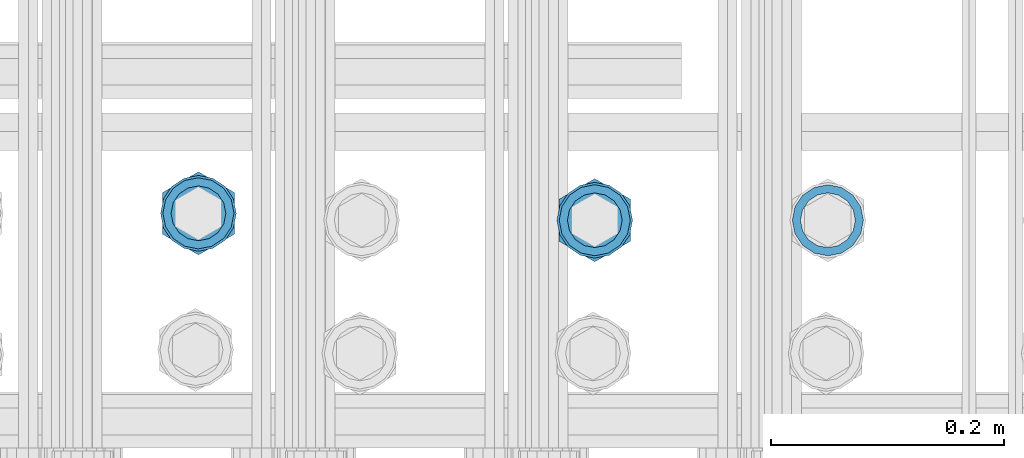
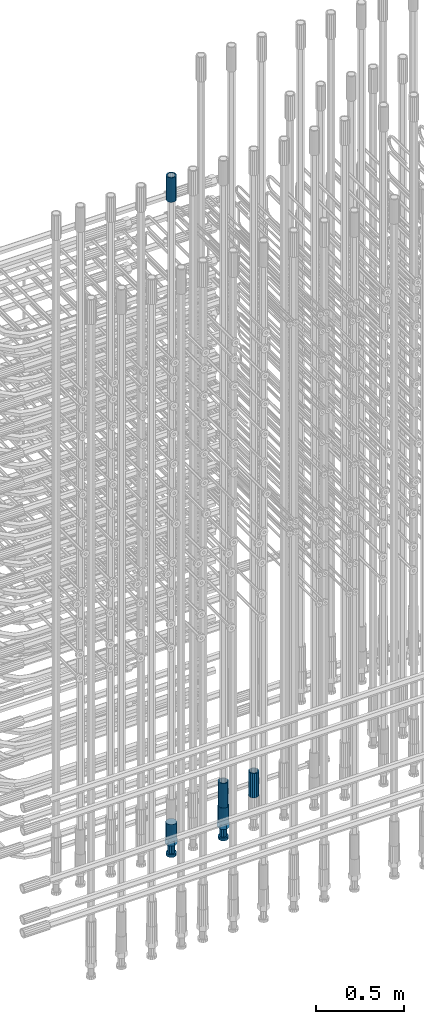
# One storey, part 40 of 177: 5 beams.
"""IFC2X3 building model written with IfcOpenShell, lengths in millimetres."""

from ifc_helpers import new_model, si_unit, frame, origin_with_axes, place, context, subcontext, project, spatial, faceted_brep, material, type_object, element, save


model = new_model("IFC2X3")

# Units and contexts
model_context_1 = context("Model", 3, precision=1e-05, world=origin_with_axes())
model_context_2 = context("Model", 3, precision=1e-05, world=origin_with_axes())
body_context = subcontext(model_context_2, "Body", "Model", "MODEL_VIEW")
ifc_project = project(units=[si_unit("LENGTHUNIT", "METRE", prefix="MILLI"), si_unit("AREAUNIT", "SQUARE_METRE"), si_unit("VOLUMEUNIT", "CUBIC_METRE"), si_unit("MASSUNIT", "GRAM", prefix="KILO"), si_unit("TIMEUNIT", "SECOND"), si_unit("PLANEANGLEUNIT", "RADIAN"), si_unit("SOLIDANGLEUNIT", "STERADIAN"), si_unit("THERMODYNAMICTEMPERATUREUNIT", "DEGREE_CELSIUS"), si_unit("LUMINOUSINTENSITYUNIT", "LUMEN")], contexts=[model_context_1])

# Site, building, storey
site_placement = place(None, origin_with_axes())
site = spatial("IfcSite", under=ifc_project, at=site_placement, CompositionType="ELEMENT")
building_placement = place(site_placement, origin_with_axes())
building = spatial("IfcBuilding", under=site, at=building_placement, Name="Undefined", CompositionType="ELEMENT")
storey_placement = place(building_placement, origin_with_axes())
storey = spatial("IfcBuildingStorey", under=building, at=storey_placement, Name="Undefined", CompositionType="ELEMENT", Elevation=0.0)

# Beams
ifc_material = material(Name="STEEL/S275")
beam_type_1 = type_object("IfcBeamType", PredefinedType="NOTDEFINED")
beam_1_placement = place(storey_placement, frame((2030835.50306268, 6205277.49272666, 23229.9858194793), z_axis=(1.0, 0.0, 0.0), x_axis=(0.0, 0.0, 1.0)))
element("IfcBeam", 1, at=beam_1_placement, inside=storey, type_object=beam_type_1, material=ifc_material, Name="AG40N", context=body_context, shape_type="Brep", body=[
    faceted_brep([(0.0, -23.5000000001164, -9.31322574615479e-10), (0.0, -21.7111690140155, 8.99306066054851), (170.0, -21.7111690140155, 8.99306066054851), (170.0, -23.5, 0.0), (0.0, -16.6170093578839, 16.6170093575493), (170.0, -16.6170093578839, 16.6170093575493), (0.0, -8.99306066057943, 21.7111690137535), (170.0, -8.99306066057943, 21.7111690137535), (0.0, 1.16415321826935e-10, 23.5), (170.0, 0.0, 23.5), (0.0, 8.99306066057943, 21.7111690137535), (170.0, 8.99306066057943, 21.7111690137535), (0.0, 16.6170093578839, 16.6170093575493), (170.0, 16.6170093578839, 16.6170093575493), (0.0, 21.7111690140155, 8.99306066054851), (170.0, 21.7111690140155, 8.99306066054851), (0.0, 23.5000000001164, -9.31322574615479e-10), (170.0, 23.5, 0.0), (0.0, 21.7111690140155, -8.99306066054851), (170.0, 21.7111690140155, -8.99306066054851), (0.0, 16.6170093578839, -16.6170093575493), (170.0, 16.6170093578839, -16.6170093575493), (0.0, 8.99306066057943, -21.7111690137535), (170.0, 8.99306066057943, -21.7111690137535), (0.0, 1.16415321826935e-10, -23.5000000009313), (170.0, 0.0, -23.5), (0.0, -8.99306066057943, -21.7111690137535), (170.0, -8.99306066057943, -21.7111690137535), (0.0, -16.6170093578839, -16.6170093575493), (170.0, -16.6170093578839, -16.6170093575493), (0.0, -21.7111690140155, -8.99306066054851), (170.0, -21.7111690140155, -8.99306066054851), (0.0, -30.5, 0.0), (0.0, -28.1783257415937, -11.6718446873128), (170.0, -28.1783257415937, -11.6718446873128), (170.0, -30.5, 0.0), (0.0, -21.5667568261888, -21.5667568258941), (170.0, -21.5667568261888, -21.5667568258941), (0.0, -11.6718446871346, -28.1783257415518), (170.0, -11.6718446871346, -28.1783257415518), (0.0, 0.0, -30.5), (170.0, 0.0, -30.5), (0.0, 11.6718446871346, -28.1783257415518), (170.0, 11.6718446871346, -28.1783257415518), (0.0, 21.5667568261888, -21.5667568258941), (170.0, 21.5667568261888, -21.5667568258941), (0.0, 28.1783257415937, -11.6718446873128), (170.0, 28.1783257415937, -11.6718446873128), (0.0, 30.5, 0.0), (170.0, 30.5, 0.0), (0.0, 28.1783257415937, 11.6718446873128), (170.0, 28.1783257415937, 11.6718446873128), (0.0, 21.5667568261888, 21.5667568258941), (170.0, 21.5667568261888, 21.5667568258941), (0.0, 11.6718446871346, 28.1783257415518), (170.0, 11.6718446871346, 28.1783257415518), (0.0, 0.0, 30.5), (170.0, 0.0, 30.5), (0.0, -11.6718446871346, 28.1783257415518), (170.0, -11.6718446871346, 28.1783257415518), (0.0, -21.5667568261888, 21.5667568258941), (170.0, -21.5667568261888, 21.5667568258941), (0.0, -28.1783257415937, 11.6718446873128), (170.0, -28.1783257415937, 11.6718446873128)], [[[0, 1, 2, 3]], [[1, 4, 5, 2]], [[4, 6, 7, 5]], [[6, 8, 9, 7]], [[8, 10, 11, 9]], [[10, 12, 13, 11]], [[12, 14, 15, 13]], [[14, 16, 17, 15]], [[16, 18, 19, 17]], [[18, 20, 21, 19]], [[20, 22, 23, 21]], [[22, 24, 25, 23]], [[24, 26, 27, 25]], [[26, 28, 29, 27]], [[28, 30, 31, 29]], [[30, 0, 3, 31]], [[32, 33, 34, 35]], [[33, 36, 37, 34]], [[36, 38, 39, 37]], [[38, 40, 41, 39]], [[40, 42, 43, 41]], [[42, 44, 45, 43]], [[44, 46, 47, 45]], [[46, 48, 49, 47]], [[48, 50, 51, 49]], [[50, 52, 53, 51]], [[52, 54, 55, 53]], [[54, 56, 57, 55]], [[56, 58, 59, 57]], [[58, 60, 61, 59]], [[60, 62, 63, 61]], [[62, 32, 35, 63]], [[37, 39, 41, 43, 45, 47, 49, 51, 53, 55, 57, 59, 61, 63, 35, 34], [5, 7, 9, 11, 13, 15, 17, 19, 21, 23, 25, 27, 29, 31, 3, 2]], [[62, 60, 58, 56, 54, 52, 50, 48, 46, 44, 42, 40, 38, 36, 33, 32], [30, 28, 26, 24, 22, 20, 18, 16, 14, 12, 10, 8, 6, 4, 1, 0]]]),
])
beam_2_placement = place(storey_placement, frame((2031175.5032168, 6205271.57061557, 19060.9768004273), z_axis=(-1.0, 0.0, 0.0), x_axis=(0.0, 0.0, -1.0)))
element("IfcBeam", 2, at=beam_2_placement, inside=storey, type_object=beam_type_1, material=ifc_material, Name="AG40N", context=body_context, shape_type="Brep", body=[
    faceted_brep([(0.0, -23.5000000001164, -9.31322574615479e-10), (0.0, -21.7111690140155, 8.99306066054851), (170.0, -21.7111690140155, 8.99306066054851), (170.0, -23.5, 0.0), (0.0, -16.6170093578839, 16.6170093575493), (170.0, -16.6170093578839, 16.6170093575493), (0.0, -8.99306066057943, 21.7111690137535), (170.0, -8.99306066057943, 21.7111690137535), (0.0, 1.16415321826935e-10, 23.5), (170.0, 0.0, 23.5), (0.0, 8.99306066057943, 21.7111690137535), (170.0, 8.99306066057943, 21.7111690137535), (0.0, 16.6170093578839, 16.6170093575493), (170.0, 16.6170093578839, 16.6170093575493), (0.0, 21.7111690140155, 8.99306066054851), (170.0, 21.7111690140155, 8.99306066054851), (0.0, 23.5000000001164, -9.31322574615479e-10), (170.0, 23.5, 0.0), (0.0, 21.7111690140155, -8.99306066054851), (170.0, 21.7111690140155, -8.99306066054851), (0.0, 16.6170093578839, -16.6170093575493), (170.0, 16.6170093578839, -16.6170093575493), (0.0, 8.99306066057943, -21.7111690137535), (170.0, 8.99306066057943, -21.7111690137535), (0.0, 1.16415321826935e-10, -23.5000000009313), (170.0, 0.0, -23.5), (0.0, -8.99306066057943, -21.7111690137535), (170.0, -8.99306066057943, -21.7111690137535), (0.0, -16.6170093578839, -16.6170093575493), (170.0, -16.6170093578839, -16.6170093575493), (0.0, -21.7111690140155, -8.99306066054851), (170.0, -21.7111690140155, -8.99306066054851), (0.0, -30.5, 0.0), (0.0, -28.1783257415937, -11.6718446873128), (170.0, -28.1783257415937, -11.6718446873128), (170.0, -30.5, 0.0), (0.0, -21.5667568261888, -21.5667568258941), (170.0, -21.5667568261888, -21.5667568258941), (0.0, -11.6718446871346, -28.1783257415518), (170.0, -11.6718446871346, -28.1783257415518), (0.0, 0.0, -30.5), (170.0, 0.0, -30.5), (0.0, 11.6718446871346, -28.1783257415518), (170.0, 11.6718446871346, -28.1783257415518), (0.0, 21.5667568261888, -21.5667568258941), (170.0, 21.5667568261888, -21.5667568258941), (0.0, 28.1783257415937, -11.6718446873128), (170.0, 28.1783257415937, -11.6718446873128), (0.0, 30.5, 0.0), (170.0, 30.5, 0.0), (0.0, 28.1783257415937, 11.6718446873128), (170.0, 28.1783257415937, 11.6718446873128), (0.0, 21.5667568261888, 21.5667568258941), (170.0, 21.5667568261888, 21.5667568258941), (0.0, 11.6718446871346, 28.1783257415518), (170.0, 11.6718446871346, 28.1783257415518), (0.0, 0.0, 30.5), (170.0, 0.0, 30.5), (0.0, -11.6718446871346, 28.1783257415518), (170.0, -11.6718446871346, 28.1783257415518), (0.0, -21.5667568261888, 21.5667568258941), (170.0, -21.5667568261888, 21.5667568258941), (0.0, -28.1783257415937, 11.6718446873128), (170.0, -28.1783257415937, 11.6718446873128)], [[[0, 1, 2, 3]], [[1, 4, 5, 2]], [[4, 6, 7, 5]], [[6, 8, 9, 7]], [[8, 10, 11, 9]], [[10, 12, 13, 11]], [[12, 14, 15, 13]], [[14, 16, 17, 15]], [[16, 18, 19, 17]], [[18, 20, 21, 19]], [[20, 22, 23, 21]], [[22, 24, 25, 23]], [[24, 26, 27, 25]], [[26, 28, 29, 27]], [[28, 30, 31, 29]], [[30, 0, 3, 31]], [[32, 33, 34, 35]], [[33, 36, 37, 34]], [[36, 38, 39, 37]], [[38, 40, 41, 39]], [[40, 42, 43, 41]], [[42, 44, 45, 43]], [[44, 46, 47, 45]], [[46, 48, 49, 47]], [[48, 50, 51, 49]], [[50, 52, 53, 51]], [[52, 54, 55, 53]], [[54, 56, 57, 55]], [[56, 58, 59, 57]], [[58, 60, 61, 59]], [[60, 62, 63, 61]], [[62, 32, 35, 63]], [[37, 39, 41, 43, 45, 47, 49, 51, 53, 55, 57, 59, 61, 63, 35, 34], [5, 7, 9, 11, 13, 15, 17, 19, 21, 23, 25, 27, 29, 31, 3, 2]], [[62, 60, 58, 56, 54, 52, 50, 48, 46, 44, 42, 40, 38, 36, 33, 32], [30, 28, 26, 24, 22, 20, 18, 16, 14, 12, 10, 8, 6, 4, 1, 0]]]),
])
beam_3_placement = place(storey_placement, frame((2031375.50320963, 6205271.51712378, 19060.9768004272), z_axis=(-1.0, 0.0, 0.0), x_axis=(0.0, 0.0, -1.0)))
element("IfcBeam", 3, at=beam_3_placement, inside=storey, type_object=beam_type_1, material=ifc_material, Name="AG40N", context=body_context, shape_type="Brep", body=[
    faceted_brep([(0.0, -23.5000000001164, -9.31322574615479e-10), (0.0, -21.7111690140155, 8.99306066054851), (170.0, -21.7111690140155, 8.99306066054851), (170.0, -23.5, 0.0), (0.0, -16.6170093578839, 16.6170093575493), (170.0, -16.6170093578839, 16.6170093575493), (0.0, -8.99306066057943, 21.7111690137535), (170.0, -8.99306066057943, 21.7111690137535), (0.0, 1.16415321826935e-10, 23.5), (170.0, 0.0, 23.5), (0.0, 8.99306066057943, 21.7111690137535), (170.0, 8.99306066057943, 21.7111690137535), (0.0, 16.6170093578839, 16.6170093575493), (170.0, 16.6170093578839, 16.6170093575493), (0.0, 21.7111690140155, 8.99306066054851), (170.0, 21.7111690140155, 8.99306066054851), (0.0, 23.5000000001164, -9.31322574615479e-10), (170.0, 23.5, 0.0), (0.0, 21.7111690140155, -8.99306066054851), (170.0, 21.7111690140155, -8.99306066054851), (0.0, 16.6170093578839, -16.6170093575493), (170.0, 16.6170093578839, -16.6170093575493), (0.0, 8.99306066057943, -21.7111690137535), (170.0, 8.99306066057943, -21.7111690137535), (0.0, 1.16415321826935e-10, -23.5000000009313), (170.0, 0.0, -23.5), (0.0, -8.99306066057943, -21.7111690137535), (170.0, -8.99306066057943, -21.7111690137535), (0.0, -16.6170093578839, -16.6170093575493), (170.0, -16.6170093578839, -16.6170093575493), (0.0, -21.7111690140155, -8.99306066054851), (170.0, -21.7111690140155, -8.99306066054851), (0.0, -30.5, 0.0), (0.0, -28.1783257415937, -11.6718446873128), (170.0, -28.1783257415937, -11.6718446873128), (170.0, -30.5, 0.0), (0.0, -21.5667568261888, -21.5667568258941), (170.0, -21.5667568261888, -21.5667568258941), (0.0, -11.6718446871346, -28.1783257415518), (170.0, -11.6718446871346, -28.1783257415518), (0.0, 0.0, -30.5), (170.0, 0.0, -30.5), (0.0, 11.6718446871346, -28.1783257415518), (170.0, 11.6718446871346, -28.1783257415518), (0.0, 21.5667568261888, -21.5667568258941), (170.0, 21.5667568261888, -21.5667568258941), (0.0, 28.1783257415937, -11.6718446873128), (170.0, 28.1783257415937, -11.6718446873128), (0.0, 30.5, 0.0), (170.0, 30.5, 0.0), (0.0, 28.1783257415937, 11.6718446873128), (170.0, 28.1783257415937, 11.6718446873128), (0.0, 21.5667568261888, 21.5667568258941), (170.0, 21.5667568261888, 21.5667568258941), (0.0, 11.6718446871346, 28.1783257415518), (170.0, 11.6718446871346, 28.1783257415518), (0.0, 0.0, 30.5), (170.0, 0.0, 30.5), (0.0, -11.6718446871346, 28.1783257415518), (170.0, -11.6718446871346, 28.1783257415518), (0.0, -21.5667568261888, 21.5667568258941), (170.0, -21.5667568261888, 21.5667568258941), (0.0, -28.1783257415937, 11.6718446873128), (170.0, -28.1783257415937, 11.6718446873128)], [[[0, 1, 2, 3]], [[1, 4, 5, 2]], [[4, 6, 7, 5]], [[6, 8, 9, 7]], [[8, 10, 11, 9]], [[10, 12, 13, 11]], [[12, 14, 15, 13]], [[14, 16, 17, 15]], [[16, 18, 19, 17]], [[18, 20, 21, 19]], [[20, 22, 23, 21]], [[22, 24, 25, 23]], [[24, 26, 27, 25]], [[26, 28, 29, 27]], [[28, 30, 31, 29]], [[30, 0, 3, 31]], [[32, 33, 34, 35]], [[33, 36, 37, 34]], [[36, 38, 39, 37]], [[38, 40, 41, 39]], [[40, 42, 43, 41]], [[42, 44, 45, 43]], [[44, 46, 47, 45]], [[46, 48, 49, 47]], [[48, 50, 51, 49]], [[50, 52, 53, 51]], [[52, 54, 55, 53]], [[54, 56, 57, 55]], [[56, 58, 59, 57]], [[58, 60, 61, 59]], [[60, 62, 63, 61]], [[62, 32, 35, 63]], [[37, 39, 41, 43, 45, 47, 49, 51, 53, 55, 57, 59, 61, 63, 35, 34], [5, 7, 9, 11, 13, 15, 17, 19, 21, 23, 25, 27, 29, 31, 3, 2]], [[62, 60, 58, 56, 54, 52, 50, 48, 46, 44, 42, 40, 38, 36, 33, 32], [30, 28, 26, 24, 22, 20, 18, 16, 14, 12, 10, 8, 6, 4, 1, 0]]]),
])
beam_type_2 = type_object("IfcBeamType", Name="ROD65", PredefinedType="NOTDEFINED")
beam_4_placement = place(storey_placement, frame((2030835.50306269, 6205277.49272666, 18890.966800425), z_axis=(-1.0, 0.0, 0.0), x_axis=(0.0, 0.0, -1.0)))
element("IfcBeam", 4, at=beam_4_placement, inside=storey, type_object=beam_type_2, material=ifc_material, Name="AGB40", ObjectType="ROD65", context=body_context, shape_type="Brep", body=[
    faceted_brep([(117.0, 8.17543110251427, 30.873805644922), (117.0, 17.8250000001863, 30.873805644922), (117.0, 22.0056958701462, 23.6326279877685), (117.0, 12.4372115517035, 30.0260848065373), (117.0, -17.8250000001863, 30.873805644922), (150.200000000186, -17.8250000001863, 30.873805644922), (150.200000000186, 17.8250000001863, 30.873805644922), (117.0, -8.17543110251427, 30.873805644922), (117.0, -12.4372115517035, 30.0260848065373), (117.0, -22.0056958701462, 23.6326279877685), (117.0, -35.6500000003725, 0.0), (150.200000000186, -35.6500000003725, 0.0), (117.0, -30.8443150008097, 8.32369058486074), (117.0, -32.5, 0.0), (117.0, -30.8443150008097, -8.32369058462791), (117.0, -17.8250000001863, -30.873805644922), (150.200000000186, -17.8250000001863, -30.873805644922), (117.0, -22.0056958701462, -23.6326279877685), (117.0, -12.4372115517035, -30.0260848065373), (117.0, -8.17543110251427, -30.873805644922), (117.0, 17.8250000001863, -30.873805644922), (150.200000000186, 17.8250000001863, -30.873805644922), (117.0, 8.17543110251427, -30.873805644922), (117.0, 22.0056958701462, -23.6326279877685), (117.0, 12.4372115517035, -30.0260848065373), (117.0, 35.6500000003725, 0.0), (150.200000000186, 35.6500000003725, 0.0), (117.0, 30.8443150008097, -8.32369058486074), (117.0, 30.8443150008097, 8.32369058462791), (117.0, 32.5, 0.0), (0.0, -22.9809703892097, 22.9809703885621), (0.0, -30.0260848058388, 12.4372115518636), (117.0, -30.0260848067701, 12.4372115519363), (117.0, -22.9809703882784, 22.9809703885112), (-2.3283064365387e-10, 22.9809703892097, -22.9809703885639), (-4.65661287307739e-10, 30.0260848077014, -12.4372115518672), (117.0, 30.0260848067701, -12.4372115519363), (117.0, 22.9809703882784, -22.9809703885112), (-2.3283064365387e-10, -30.0260848067701, -12.4372115518672), (-2.3283064365387e-10, -22.9809703892097, -22.9809703885621), (117.0, -22.9809703882784, -22.9809703885112), (117.0, -30.0260848067701, -12.4372115519363), (-2.3283064365387e-10, -12.4372115507722, 30.0260848066137), (-2.3283064365387e-10, 9.31322574615479e-10, 32.4999999999982), (-2.3283064365387e-10, 12.4372115526348, 30.0260848066137), (0.0, 22.9809703892097, 22.9809703885621), (-2.3283064365387e-10, 30.0260848077014, 12.4372115518636), (-2.3283064365387e-10, 32.5, 0.0), (-2.3283064365387e-10, 12.4372115526348, -30.0260848066173), (-2.3283064365387e-10, 9.31322574615479e-10, -32.5), (-2.3283064365387e-10, -12.4372115517035, -30.0260848066173), (-4.65661287307739e-10, -32.4999999990687, -1.81898940354586e-12), (117.0, 22.9809703882784, 22.9809703885112), (117.0, 30.0260848067701, 12.4372115519363), (117.0, 0.0, -32.5), (117.0, 0.0, 32.5), (150.200000000186, 10.5, -18.1865334794857), (150.200000000186, 0.0, -21.0), (150.200000000186, -10.5, -18.1865334794857), (150.200000000186, -18.18653347902, -10.5), (150.200000000186, -21.0, 0.0), (150.200000000186, -18.18653347902, 10.5), (150.200000000186, -10.5, 18.1865334794857), (150.200000000186, 0.0, 21.0), (150.200000000186, 10.5, 18.1865334794857), (150.200000000186, 18.18653347902, 10.5), (150.200000000186, 21.0, 0.0), (150.200000000186, 18.18653347902, -10.5), (210.980000000447, -10.5, -18.1865334794857), (210.980000000447, 0.0, -21.0), (210.980000000447, -18.18653347902, -10.5), (210.980000000447, -21.0, 0.0), (210.980000000447, -18.18653347902, 10.5), (210.980000000447, -10.5, 18.1865334794857), (210.980000000447, 0.0, 21.0), (210.980000000447, 10.5, 18.1865334794857), (210.980000000447, 18.18653347902, 10.5), (210.980000000447, 21.0, 0.0), (210.980000000447, 18.18653347902, -10.5), (210.980000000447, 10.5, -18.1865334794857), (211.001368442696, -27.7269937992096, -11.491116326768), (211.003082550167, -21.2238094303757, -21.223815418547), (231.002518367059, -21.2131944671273, -21.2132004550658), (231.000804259587, -27.7163788359612, -11.4805013632867), (211.001368440451, -11.4911085031927, -27.7269970395137), (231.000804257343, -11.4804935399443, -27.7163820760325), (210.996487071217, -0.0106065049767494, -30.0106107392348), (230.995922888109, 8.45827162265778e-06, -29.9999957757536), (210.989181586672, 11.46989420522, -27.7269970329944), (230.988617403564, 11.4805091684684, -27.7163820695132), (210.980564180623, 21.2025914648548, -21.2238154064398), (230.979999997515, 21.2132064281031, -21.2132004429586), (210.971946775022, 27.7057703435421, -11.4911163107026), (230.971382591913, 27.7163853067905, -11.4805013472214), (210.96464129175, 29.9893808094785, -0.0106149562634528), (230.964077108642, 29.9999957727268, 7.21774995326996e-09), (210.959759924415, 27.7057638689876, 11.4698863970116), (230.959195741307, 27.7163788322359, 11.4805013604928), (210.958045816944, 21.2025795001537, 21.2025854887906), (230.957481633835, 21.213194463402, 21.2132004522718), (210.95975992666, 11.4698785729706, 27.7057671097573), (230.959195743551, 11.480493536219, 27.7163820732385), (210.964641295894, -0.010623425245285, 29.9893808094785), (230.964077112785, -8.46199691295624e-06, 29.9999957729597), (210.971946780439, -11.4911241354421, 27.705767103238), (230.97138259733, -11.4805091721937, 27.7163820667192), (210.980564186488, -21.2238213950768, 21.2025854766835), (230.980000003379, -21.2132064318284, 21.2132004401647), (210.989181592089, -27.7270002737641, 11.4698863809463), (230.988617408981, -27.7163853105158, 11.4805013444275), (210.996487075361, -30.0106107397005, -0.0106149734929204), (230.995922892253, -29.9999957764521, -1.00117176771164e-08)], [[[0, 1, 2, 3]], [[4, 5, 6, 1, 0, 7]], [[4, 7, 8, 9]], [[10, 11, 5, 4, 9, 12]], [[10, 12, 13, 14]], [[15, 16, 11, 10, 14, 17]], [[15, 17, 18, 19]], [[20, 21, 16, 15, 19, 22]], [[23, 20, 22, 24]], [[25, 26, 21, 20, 23, 27]], [[28, 25, 27, 29]], [[30, 31, 32, 33]], [[34, 35, 36, 37]], [[38, 39, 40, 41]], [[31, 30, 42, 43, 44, 45, 46, 47, 35, 34, 48, 49, 50, 39, 38, 51]], [[46, 45, 52, 53]], [[29, 47, 46, 53, 28]], [[27, 36, 35, 47, 29]], [[23, 37, 36, 27]], [[24, 48, 34, 37, 23]], [[22, 54, 49, 48, 24]], [[19, 54, 22]], [[18, 50, 49, 54, 19]], [[17, 40, 39, 50, 18]], [[14, 41, 40, 17]], [[13, 51, 38, 41, 14]], [[12, 32, 31, 51, 13]], [[9, 33, 32, 12]], [[8, 42, 30, 33, 9]], [[7, 55, 43, 42, 8]], [[0, 55, 7]], [[3, 44, 43, 55, 0]], [[2, 52, 45, 44, 3]], [[28, 53, 52, 2]], [[1, 6, 26, 25, 28, 2]], [[5, 11, 16, 21, 26, 6], [56, 57, 58, 59, 60, 61, 62, 63, 64, 65, 66, 67]], [[68, 58, 57, 69]], [[70, 59, 58, 68]], [[71, 60, 59, 70]], [[72, 61, 60, 71]], [[73, 62, 61, 72]], [[74, 63, 62, 73]], [[75, 64, 63, 74]], [[76, 65, 64, 75]], [[77, 66, 65, 76]], [[78, 67, 66, 77]], [[79, 56, 67, 78]], [[69, 57, 56, 79]], [[80, 81, 82, 83]], [[81, 84, 85, 82]], [[84, 86, 87, 85]], [[86, 88, 89, 87]], [[88, 90, 91, 89]], [[90, 92, 93, 91]], [[92, 94, 95, 93]], [[94, 96, 97, 95]], [[96, 98, 99, 97]], [[98, 100, 101, 99]], [[100, 102, 103, 101]], [[102, 104, 105, 103]], [[104, 106, 107, 105]], [[106, 108, 109, 107]], [[108, 110, 111, 109]], [[82, 85, 87, 89, 91, 93, 95, 97, 99, 101, 103, 105, 107, 109, 111, 83]], [[110, 80, 83, 111]], [[108, 106, 104, 102, 100, 98, 96, 94, 92, 90, 88, 86, 84, 81, 80, 110], [78, 77, 76, 75, 74, 73, 72, 71, 70, 68, 69, 79]]]),
])
beam_5_placement = place(storey_placement, frame((2031175.50321679, 6205271.57061557, 18890.9768004273), z_axis=(-1.0, 0.0, 0.0), x_axis=(0.0, 0.0, -1.0)))
element("IfcBeam", 5, at=beam_5_placement, inside=storey, type_object=beam_type_2, material=ifc_material, Name="AGB40", ObjectType="ROD65", context=body_context, shape_type="Brep", body=[
    faceted_brep([(117.0, 8.17543110251427, 30.873805644922), (117.0, 17.8250000001863, 30.873805644922), (117.0, 22.0056958701462, 23.6326279877685), (117.0, 12.4372115517035, 30.0260848065373), (117.0, -17.8250000001863, 30.873805644922), (150.200000000186, -17.8250000001863, 30.873805644922), (150.200000000186, 17.8250000001863, 30.873805644922), (117.0, -8.17543110251427, 30.873805644922), (117.0, -12.4372115517035, 30.0260848065373), (117.0, -22.0056958701462, 23.6326279877685), (117.0, -35.6500000003725, 0.0), (150.200000000186, -35.6500000003725, 0.0), (117.0, -30.8443150008097, 8.32369058486074), (117.0, -32.5, 0.0), (117.0, -30.8443150008097, -8.32369058462791), (117.0, -17.8250000001863, -30.873805644922), (150.200000000186, -17.8250000001863, -30.873805644922), (117.0, -22.0056958701462, -23.6326279877685), (117.0, -12.4372115517035, -30.0260848065373), (117.0, -8.17543110251427, -30.873805644922), (117.0, 17.8250000001863, -30.873805644922), (150.200000000186, 17.8250000001863, -30.873805644922), (117.0, 8.17543110251427, -30.873805644922), (117.0, 22.0056958701462, -23.6326279877685), (117.0, 12.4372115517035, -30.0260848065373), (117.0, 35.6500000003725, 0.0), (150.200000000186, 35.6500000003725, 0.0), (117.0, 30.8443150008097, -8.32369058486074), (117.0, 30.8443150008097, 8.32369058462791), (117.0, 32.5, 0.0), (0.0, -22.9809703892097, 22.9809703885621), (0.0, -30.0260848058388, 12.4372115518636), (117.0, -30.0260848067701, 12.4372115519363), (117.0, -22.9809703882784, 22.9809703885112), (-2.3283064365387e-10, 22.9809703892097, -22.9809703885639), (-4.65661287307739e-10, 30.0260848077014, -12.4372115518672), (117.0, 30.0260848067701, -12.4372115519363), (117.0, 22.9809703882784, -22.9809703885112), (-2.3283064365387e-10, -30.0260848067701, -12.4372115518672), (-2.3283064365387e-10, -22.9809703892097, -22.9809703885621), (117.0, -22.9809703882784, -22.9809703885112), (117.0, -30.0260848067701, -12.4372115519363), (-2.3283064365387e-10, -12.4372115507722, 30.0260848066137), (-2.3283064365387e-10, 9.31322574615479e-10, 32.4999999999982), (-2.3283064365387e-10, 12.4372115526348, 30.0260848066137), (0.0, 22.9809703892097, 22.9809703885621), (-2.3283064365387e-10, 30.0260848077014, 12.4372115518636), (-2.3283064365387e-10, 32.5, 0.0), (-2.3283064365387e-10, 12.4372115526348, -30.0260848066173), (-2.3283064365387e-10, 9.31322574615479e-10, -32.5), (-2.3283064365387e-10, -12.4372115517035, -30.0260848066173), (-4.65661287307739e-10, -32.4999999990687, -1.81898940354586e-12), (117.0, 22.9809703882784, 22.9809703885112), (117.0, 30.0260848067701, 12.4372115519363), (117.0, 0.0, -32.5), (117.0, 0.0, 32.5), (150.200000000186, 10.5, -18.1865334794857), (150.200000000186, 0.0, -21.0), (150.200000000186, -10.5, -18.1865334794857), (150.200000000186, -18.18653347902, -10.5), (150.200000000186, -21.0, 0.0), (150.200000000186, -18.18653347902, 10.5), (150.200000000186, -10.5, 18.1865334794857), (150.200000000186, 0.0, 21.0), (150.200000000186, 10.5, 18.1865334794857), (150.200000000186, 18.18653347902, 10.5), (150.200000000186, 21.0, 0.0), (150.200000000186, 18.18653347902, -10.5), (210.980000000447, -10.5, -18.1865334794857), (210.980000000447, 0.0, -21.0), (210.980000000447, -18.18653347902, -10.5), (210.980000000447, -21.0, 0.0), (210.980000000447, -18.18653347902, 10.5), (210.980000000447, -10.5, 18.1865334794857), (210.980000000447, 0.0, 21.0), (210.980000000447, 10.5, 18.1865334794857), (210.980000000447, 18.18653347902, 10.5), (210.980000000447, 21.0, 0.0), (210.980000000447, 18.18653347902, -10.5), (210.980000000447, 10.5, -18.1865334794857), (211.001368442696, -27.7269937992096, -11.491116326768), (211.003082550167, -21.2238094303757, -21.223815418547), (231.002518367059, -21.2131944671273, -21.2132004550658), (231.000804259587, -27.7163788359612, -11.4805013632867), (211.001368440451, -11.4911085031927, -27.7269970395137), (231.000804257343, -11.4804935399443, -27.7163820760325), (210.996487071217, -0.0106065049767494, -30.0106107392348), (230.995922888109, 8.45827162265778e-06, -29.9999957757536), (210.989181586672, 11.46989420522, -27.7269970329944), (230.988617403564, 11.4805091684684, -27.7163820695132), (210.980564180623, 21.2025914648548, -21.2238154064398), (230.979999997515, 21.2132064281031, -21.2132004429586), (210.971946775022, 27.7057703435421, -11.4911163107026), (230.971382591913, 27.7163853067905, -11.4805013472214), (210.96464129175, 29.9893808094785, -0.0106149562634528), (230.964077108642, 29.9999957727268, 7.21774995326996e-09), (210.959759924415, 27.7057638689876, 11.4698863970116), (230.959195741307, 27.7163788322359, 11.4805013604928), (210.958045816944, 21.2025795001537, 21.2025854887906), (230.957481633835, 21.213194463402, 21.2132004522718), (210.95975992666, 11.4698785729706, 27.7057671097573), (230.959195743551, 11.480493536219, 27.7163820732385), (210.964641295894, -0.010623425245285, 29.9893808094785), (230.964077112785, -8.46199691295624e-06, 29.9999957729597), (210.971946780439, -11.4911241354421, 27.705767103238), (230.97138259733, -11.4805091721937, 27.7163820667192), (210.980564186488, -21.2238213950768, 21.2025854766835), (230.980000003379, -21.2132064318284, 21.2132004401647), (210.989181592089, -27.7270002737641, 11.4698863809463), (230.988617408981, -27.7163853105158, 11.4805013444275), (210.996487075361, -30.0106107397005, -0.0106149734929204), (230.995922892253, -29.9999957764521, -1.00117176771164e-08)], [[[0, 1, 2, 3]], [[4, 5, 6, 1, 0, 7]], [[4, 7, 8, 9]], [[10, 11, 5, 4, 9, 12]], [[10, 12, 13, 14]], [[15, 16, 11, 10, 14, 17]], [[15, 17, 18, 19]], [[20, 21, 16, 15, 19, 22]], [[23, 20, 22, 24]], [[25, 26, 21, 20, 23, 27]], [[28, 25, 27, 29]], [[30, 31, 32, 33]], [[34, 35, 36, 37]], [[38, 39, 40, 41]], [[31, 30, 42, 43, 44, 45, 46, 47, 35, 34, 48, 49, 50, 39, 38, 51]], [[46, 45, 52, 53]], [[29, 47, 46, 53, 28]], [[27, 36, 35, 47, 29]], [[23, 37, 36, 27]], [[24, 48, 34, 37, 23]], [[22, 54, 49, 48, 24]], [[19, 54, 22]], [[18, 50, 49, 54, 19]], [[17, 40, 39, 50, 18]], [[14, 41, 40, 17]], [[13, 51, 38, 41, 14]], [[12, 32, 31, 51, 13]], [[9, 33, 32, 12]], [[8, 42, 30, 33, 9]], [[7, 55, 43, 42, 8]], [[0, 55, 7]], [[3, 44, 43, 55, 0]], [[2, 52, 45, 44, 3]], [[28, 53, 52, 2]], [[1, 6, 26, 25, 28, 2]], [[5, 11, 16, 21, 26, 6], [56, 57, 58, 59, 60, 61, 62, 63, 64, 65, 66, 67]], [[68, 58, 57, 69]], [[70, 59, 58, 68]], [[71, 60, 59, 70]], [[72, 61, 60, 71]], [[73, 62, 61, 72]], [[74, 63, 62, 73]], [[75, 64, 63, 74]], [[76, 65, 64, 75]], [[77, 66, 65, 76]], [[78, 67, 66, 77]], [[79, 56, 67, 78]], [[69, 57, 56, 79]], [[80, 81, 82, 83]], [[81, 84, 85, 82]], [[84, 86, 87, 85]], [[86, 88, 89, 87]], [[88, 90, 91, 89]], [[90, 92, 93, 91]], [[92, 94, 95, 93]], [[94, 96, 97, 95]], [[96, 98, 99, 97]], [[98, 100, 101, 99]], [[100, 102, 103, 101]], [[102, 104, 105, 103]], [[104, 106, 107, 105]], [[106, 108, 109, 107]], [[108, 110, 111, 109]], [[82, 85, 87, 89, 91, 93, 95, 97, 99, 101, 103, 105, 107, 109, 111, 83]], [[110, 80, 83, 111]], [[108, 106, 104, 102, 100, 98, 96, 94, 92, 90, 88, 86, 84, 81, 80, 110], [78, 77, 76, 75, 74, 73, 72, 71, 70, 68, 69, 79]]]),
])

save(model, "model.ifc")
